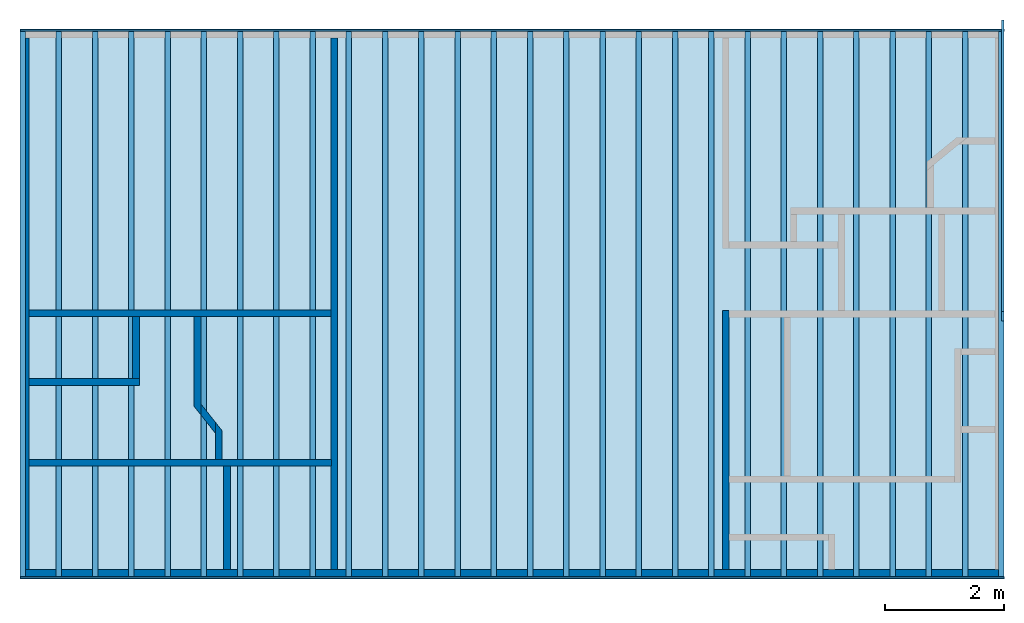
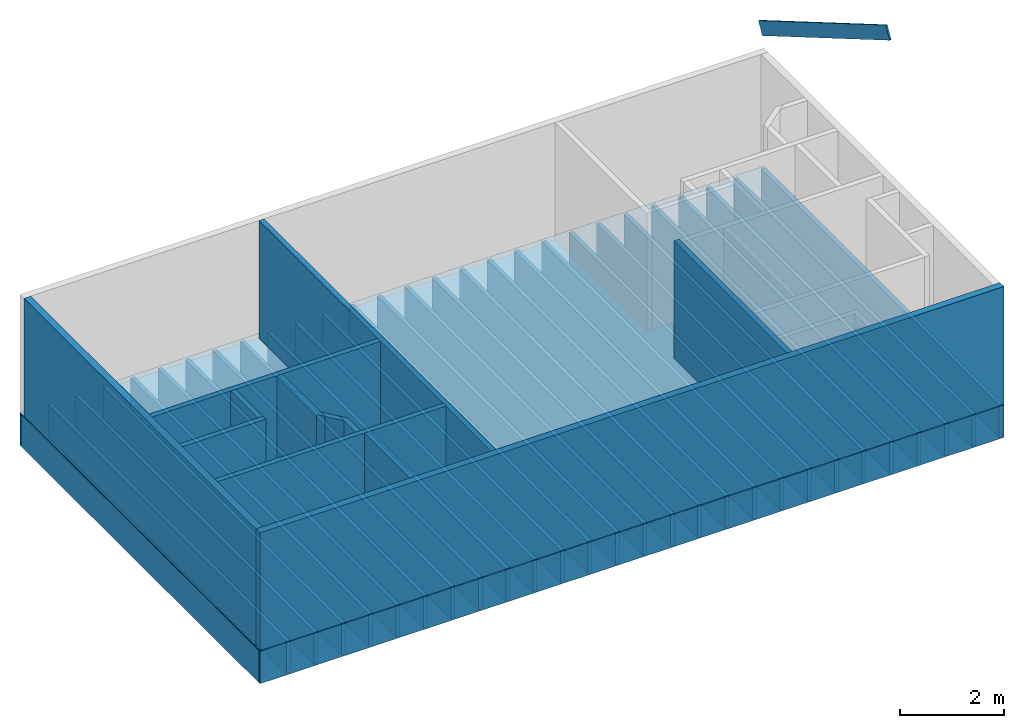
# One storey, part 1 of 2: 30 beams, 12 walls, 3 members, 1 slab.
"""IFC4 building model written with IfcOpenShell, lengths in inches."""

from ifc_helpers import new_model, entity, si_unit, converted_unit, frame, origin_with_axes, origin_2d_with_axis, place, context, subcontext, project, spatial, line, indexed_curve, outline, extrude, clip, halfspace, material, layer, layer_set, layer_usage, type_object, element, save


model = new_model("IFC4")

# Units and contexts
model_context = context("Model", 3, precision=1e-05, world=origin_with_axes())
plan_context = context("Plan", 2, precision=1e-05, world=origin_2d_with_axis())
body_context = subcontext(model_context, "Body", "Model", "MODEL_VIEW")
ifc_project = project(units=[converted_unit("PLANEANGLEUNIT", "degree", entity("IfcReal", 0.0174532925199433), si_unit("PLANEANGLEUNIT", "RADIAN"), dimensions=[0, 0, 0, 0, 0, 0, 0]), converted_unit("AREAUNIT", "square inch", entity("IfcReal", 0.0006452), si_unit("AREAUNIT", "SQUARE_METRE"), dimensions=[2, 0, 0, 0, 0, 0, 0]), converted_unit("LENGTHUNIT", "inch", entity("IfcReal", 0.0254), si_unit("LENGTHUNIT", "METRE"), dimensions=[1, 0, 0, 0, 0, 0, 0]), converted_unit("VOLUMEUNIT", "cubic inch", entity("IfcReal", 1.639e-05), si_unit("VOLUMEUNIT", "CUBIC_METRE"), dimensions=[3, 0, 0, 0, 0, 0, 0])], contexts=[model_context, plan_context])

# Site, building, storey
site_placement = place(None, origin_with_axes())
site = spatial("IfcSite", under=ifc_project, at=site_placement)
building_placement = place(site_placement, frame((0.0, 0.0, 109.012492998378), z_axis=(0.0, 0.0, 1.0), x_axis=(1.0, 0.0, 0.0)))
building = spatial("IfcBuilding", under=site, at=building_placement, Name="Building")
storey_placement = place(building_placement, frame((0.0, 0.0, -109.012492998378), z_axis=(0.0, 0.0, 1.0), x_axis=(1.0, 0.0, 0.0)))
storey = spatial("IfcBuildingStorey", under=building, at=storey_placement, Name="1st Floor")

# Beams
ifc_material = material(Name="Default")
ifc_layer_1 = layer(ifc_material, 1.25, Name="1.25in rim joist")
ifc_layer_set_1 = layer_set([ifc_layer_1], Name="1.25in rim joist")
ifc_layer_usage_1 = layer_usage(ifc_layer_set_1, "AXIS2", "POSITIVE", 0.0)
beam_type_1 = type_object("IfcBeamType", Name="1.25in rim joist", PredefinedType="JOIST", material=ifc_layer_set_1)
beam_1_placement = place(storey_placement, frame((-18.4998631946684, 4.74999974093099, -30.7187508410356), z_axis=(0.0, 0.0, 1.0), x_axis=(1.0, 0.0, 0.0)))
element("IfcBeam", 1, at=beam_1_placement, inside=storey, type_object=beam_type_1, material=ifc_layer_usage_1, Name="Beam", PredefinedType="NOTDEFINED", context=body_context, shape_type="SweptSolid", body=[
    extrude(outline(indexed_curve([(0.0, 0.0), (0.0, 1.25), (651.499983345347, 1.25), (651.499983345347, 0.0), (0.0, 0.0)], self_intersect=False)), origin_with_axes(), (0.0, 0.0, 1.0), 30.0),
])
ifc_layer_usage_2 = layer_usage(ifc_layer_set_1, "AXIS2", "POSITIVE", 0.0)
beam_2_placement = place(storey_placement, frame((-18.4998631946684, -357.879090496874, -30.7187508410356), z_axis=(0.0, 0.0, 1.0), x_axis=(1.0, 0.0, 0.0)))
element("IfcBeam", 2, at=beam_2_placement, inside=storey, type_object=beam_type_1, material=ifc_layer_usage_2, Name="Beam", PredefinedType="NOTDEFINED", context=body_context, shape_type="SweptSolid", body=[
    extrude(outline(indexed_curve([(0.0, 0.0), (0.0, 1.25), (651.499983345347, 1.25), (651.499983345347, 0.0), (0.0, 0.0)], self_intersect=False)), origin_with_axes(), (0.0, 0.0, 1.0), 30.0),
])
ifc_layer_2 = layer(ifc_material, 3.5, Name="FloorTruss 3.5 in top/bottom")
ifc_layer_set_2 = layer_set([ifc_layer_2], Name="FloorTruss 3.5 in top/bottom")
ifc_layer_usage_3 = layer_usage(ifc_layer_set_2, "AXIS2", "POSITIVE", 0.0)
beam_type_2 = type_object("IfcBeamType", Name="FloorTruss 3.5 in top/bottom", PredefinedType="JOIST", material=ifc_layer_set_2)
beam_3_placement = place(storey_placement, frame((104.999683034702, -356.628650755394, -30.7187508410356), z_axis=(0.0, 0.0, 1.0), x_axis=(3.13916473260178e-07, 1.0, 0.0)))
element("IfcBeam", 3, at=beam_3_placement, inside=storey, type_object=beam_type_2, material=ifc_layer_usage_3, Name="Beam", PredefinedType="NOTDEFINED", context=body_context, shape_type="SweptSolid", body=[
    extrude(outline(indexed_curve([(0.0, 0.0), (0.0, 3.5), (361.378694567074, 3.5), (361.378694567074, 0.0), (0.0, 0.0)], self_intersect=False)), origin_with_axes(), (0.0, 0.0, 1.0), 30.0),
])
ifc_layer_usage_4 = layer_usage(ifc_layer_set_2, "AXIS2", "POSITIVE", 0.0)
beam_4_placement = place(storey_placement, frame((128.999676291398, -356.628650755394, -30.7187508410356), z_axis=(0.0, 0.0, 1.0), x_axis=(3.13916473260178e-07, 1.0, 0.0)))
element("IfcBeam", 4, at=beam_4_placement, inside=storey, type_object=beam_type_2, material=ifc_layer_usage_4, Name="Beam", PredefinedType="NOTDEFINED", context=body_context, shape_type="SweptSolid", body=[
    extrude(outline(indexed_curve([(0.0, 0.0), (0.0, 3.5), (361.378694567074, 3.5), (361.378694567074, 0.0), (0.0, 0.0)], self_intersect=False)), origin_with_axes(), (0.0, 0.0, 1.0), 30.0),
])
ifc_layer_usage_5 = layer_usage(ifc_layer_set_2, "AXIS2", "POSITIVE", 0.0)
beam_5_placement = place(storey_placement, frame((152.999669548095, -356.628650755394, -30.7187508410356), z_axis=(0.0, 0.0, 1.0), x_axis=(3.13916473260178e-07, 1.0, 0.0)))
element("IfcBeam", 5, at=beam_5_placement, inside=storey, type_object=beam_type_2, material=ifc_layer_usage_5, Name="Beam", PredefinedType="NOTDEFINED", context=body_context, shape_type="SweptSolid", body=[
    extrude(outline(indexed_curve([(0.0, 0.0), (0.0, 3.5), (361.378694567074, 3.5), (361.378694567074, 0.0), (0.0, 0.0)], self_intersect=False)), origin_with_axes(), (0.0, 0.0, 1.0), 30.0),
])
ifc_layer_usage_6 = layer_usage(ifc_layer_set_2, "AXIS2", "POSITIVE", 0.0)
beam_6_placement = place(storey_placement, frame((176.999662804791, -356.628650755394, -30.7187508410356), z_axis=(0.0, 0.0, 1.0), x_axis=(3.13916473260178e-07, 1.0, 0.0)))
element("IfcBeam", 6, at=beam_6_placement, inside=storey, type_object=beam_type_2, material=ifc_layer_usage_6, Name="Beam", PredefinedType="NOTDEFINED", context=body_context, shape_type="SweptSolid", body=[
    extrude(outline(indexed_curve([(0.0, 0.0), (0.0, 3.5), (361.378694567074, 3.5), (361.378694567074, 0.0), (0.0, 0.0)], self_intersect=False)), origin_with_axes(), (0.0, 0.0, 1.0), 30.0),
])
ifc_layer_usage_7 = layer_usage(ifc_layer_set_2, "AXIS2", "POSITIVE", 0.0)
beam_7_placement = place(storey_placement, frame((200.999665448046, -356.628650755394, -30.7187508410356), z_axis=(0.0, 0.0, 1.0), x_axis=(3.13916473260178e-07, 1.0, 0.0)))
element("IfcBeam", 7, at=beam_7_placement, inside=storey, type_object=beam_type_2, material=ifc_layer_usage_7, Name="Beam", PredefinedType="NOTDEFINED", context=body_context, shape_type="SweptSolid", body=[
    extrude(outline(indexed_curve([(0.0, 0.0), (0.0, 3.5), (361.378694567074, 3.5), (361.378694567074, 0.0), (0.0, 0.0)], self_intersect=False)), origin_with_axes(), (0.0, 0.0, 1.0), 30.0),
])
ifc_layer_usage_8 = layer_usage(ifc_layer_set_2, "AXIS2", "POSITIVE", 0.0)
beam_8_placement = place(storey_placement, frame((224.999668091301, -356.628650755394, -30.7187508410356), z_axis=(0.0, 0.0, 1.0), x_axis=(3.13916473260178e-07, 1.0, 0.0)))
element("IfcBeam", 8, at=beam_8_placement, inside=storey, type_object=beam_type_2, material=ifc_layer_usage_8, Name="Beam", PredefinedType="NOTDEFINED", context=body_context, shape_type="SweptSolid", body=[
    extrude(outline(indexed_curve([(0.0, 0.0), (0.0, 3.5), (361.378694567074, 3.5), (361.378694567074, 0.0), (0.0, 0.0)], self_intersect=False)), origin_with_axes(), (0.0, 0.0, 1.0), 30.0),
])
ifc_layer_usage_9 = layer_usage(ifc_layer_set_2, "AXIS2", "POSITIVE", 0.0)
beam_9_placement = place(storey_placement, frame((248.999670734556, -356.628650755394, -30.7187508410356), z_axis=(0.0, 0.0, 1.0), x_axis=(3.13916473260178e-07, 1.0, 0.0)))
element("IfcBeam", 9, at=beam_9_placement, inside=storey, type_object=beam_type_2, material=ifc_layer_usage_9, Name="Beam", PredefinedType="NOTDEFINED", context=body_context, shape_type="SweptSolid", body=[
    extrude(outline(indexed_curve([(0.0, 0.0), (0.0, 3.5), (361.378694567074, 3.5), (361.378694567074, 0.0), (0.0, 0.0)], self_intersect=False)), origin_with_axes(), (0.0, 0.0, 1.0), 30.0),
])
ifc_layer_usage_10 = layer_usage(ifc_layer_set_2, "AXIS2", "POSITIVE", 0.0)
beam_10_placement = place(storey_placement, frame((272.99967337781, -356.628650755394, -30.7187508410356), z_axis=(0.0, 0.0, 1.0), x_axis=(3.13916473260178e-07, 1.0, 0.0)))
element("IfcBeam", 10, at=beam_10_placement, inside=storey, type_object=beam_type_2, material=ifc_layer_usage_10, Name="Beam", PredefinedType="NOTDEFINED", context=body_context, shape_type="SweptSolid", body=[
    extrude(outline(indexed_curve([(0.0, 0.0), (0.0, 3.5), (361.378694567074, 3.5), (361.378694567074, 0.0), (0.0, 0.0)], self_intersect=False)), origin_with_axes(), (0.0, 0.0, 1.0), 30.0),
])
ifc_layer_usage_11 = layer_usage(ifc_layer_set_2, "AXIS2", "POSITIVE", 0.0)
beam_11_placement = place(storey_placement, frame((296.999676021065, -356.628650755394, -30.7187508410356), z_axis=(0.0, 0.0, 1.0), x_axis=(3.13916473260178e-07, 1.0, 0.0)))
element("IfcBeam", 11, at=beam_11_placement, inside=storey, type_object=beam_type_2, material=ifc_layer_usage_11, Name="Beam", PredefinedType="NOTDEFINED", context=body_context, shape_type="SweptSolid", body=[
    extrude(outline(indexed_curve([(0.0, 0.0), (0.0, 3.5), (361.378694567074, 3.5), (361.378694567074, 0.0), (0.0, 0.0)], self_intersect=False)), origin_with_axes(), (0.0, 0.0, 1.0), 30.0),
])
ifc_layer_usage_12 = layer_usage(ifc_layer_set_2, "AXIS2", "POSITIVE", 0.0)
beam_12_placement = place(storey_placement, frame((320.99967866432, -356.628650755394, -30.7187508410356), z_axis=(0.0, 0.0, 1.0), x_axis=(3.13916473260178e-07, 1.0, 0.0)))
element("IfcBeam", 12, at=beam_12_placement, inside=storey, type_object=beam_type_2, material=ifc_layer_usage_12, Name="Beam", PredefinedType="NOTDEFINED", context=body_context, shape_type="SweptSolid", body=[
    extrude(outline(indexed_curve([(0.0, 0.0), (0.0, 3.5), (361.378694567074, 3.5), (361.378694567074, 0.0), (0.0, 0.0)], self_intersect=False)), origin_with_axes(), (0.0, 0.0, 1.0), 30.0),
])
ifc_layer_usage_13 = layer_usage(ifc_layer_set_2, "AXIS2", "POSITIVE", 0.0)
beam_13_placement = place(storey_placement, frame((344.999681307575, -356.628650755394, -30.7187508410356), z_axis=(0.0, 0.0, 1.0), x_axis=(3.13916473260178e-07, 1.0, 0.0)))
element("IfcBeam", 13, at=beam_13_placement, inside=storey, type_object=beam_type_2, material=ifc_layer_usage_13, Name="Beam", PredefinedType="NOTDEFINED", context=body_context, shape_type="SweptSolid", body=[
    extrude(outline(indexed_curve([(0.0, 0.0), (0.0, 3.5), (361.378694567074, 3.5), (361.378694567074, 0.0), (0.0, 0.0)], self_intersect=False)), origin_with_axes(), (0.0, 0.0, 1.0), 30.0),
])
ifc_layer_usage_14 = layer_usage(ifc_layer_set_2, "AXIS2", "POSITIVE", 0.0)
beam_14_placement = place(storey_placement, frame((368.999721497063, -356.628650755394, -30.7187508410356), z_axis=(0.0, 0.0, 1.0), x_axis=(3.13916473260178e-07, 1.0, 0.0)))
element("IfcBeam", 14, at=beam_14_placement, inside=storey, type_object=beam_type_2, material=ifc_layer_usage_14, Name="Beam", PredefinedType="NOTDEFINED", context=body_context, shape_type="SweptSolid", body=[
    extrude(outline(indexed_curve([(0.0, 0.0), (0.0, 3.5), (361.378694567074, 3.5), (361.378694567074, 0.0), (0.0, 0.0)], self_intersect=False)), origin_with_axes(), (0.0, 0.0, 1.0), 30.0),
])
ifc_layer_usage_15 = layer_usage(ifc_layer_set_2, "AXIS2", "POSITIVE", 0.0)
beam_15_placement = place(storey_placement, frame((392.999724140317, -356.628650755394, -30.7187508410356), z_axis=(0.0, 0.0, 1.0), x_axis=(3.13916473260178e-07, 1.0, 0.0)))
element("IfcBeam", 15, at=beam_15_placement, inside=storey, type_object=beam_type_2, material=ifc_layer_usage_15, Name="Beam", PredefinedType="NOTDEFINED", context=body_context, shape_type="SweptSolid", body=[
    extrude(outline(indexed_curve([(0.0, 0.0), (0.0, 3.5), (361.378694567074, 3.5), (361.378694567074, 0.0), (0.0, 0.0)], self_intersect=False)), origin_with_axes(), (0.0, 0.0, 1.0), 30.0),
])
ifc_layer_usage_16 = layer_usage(ifc_layer_set_2, "AXIS2", "POSITIVE", 0.0)
beam_16_placement = place(storey_placement, frame((416.999726783572, -356.628650755394, -30.7187508410356), z_axis=(0.0, 0.0, 1.0), x_axis=(3.13916473260178e-07, 1.0, 0.0)))
element("IfcBeam", 16, at=beam_16_placement, inside=storey, type_object=beam_type_2, material=ifc_layer_usage_16, Name="Beam", PredefinedType="NOTDEFINED", context=body_context, shape_type="SweptSolid", body=[
    extrude(outline(indexed_curve([(0.0, 0.0), (0.0, 3.5), (361.378694567074, 3.5), (361.378694567074, 0.0), (0.0, 0.0)], self_intersect=False)), origin_with_axes(), (0.0, 0.0, 1.0), 30.0),
])
ifc_layer_usage_17 = layer_usage(ifc_layer_set_2, "AXIS2", "POSITIVE", 0.0)
beam_17_placement = place(storey_placement, frame((440.999729426827, -356.628650755394, -30.7187508410356), z_axis=(0.0, 0.0, 1.0), x_axis=(3.13916473260178e-07, 1.0, 0.0)))
element("IfcBeam", 17, at=beam_17_placement, inside=storey, type_object=beam_type_2, material=ifc_layer_usage_17, Name="Beam", PredefinedType="NOTDEFINED", context=body_context, shape_type="SweptSolid", body=[
    extrude(outline(indexed_curve([(0.0, 0.0), (0.0, 3.5), (361.378694567074, 3.5), (361.378694567074, 0.0), (0.0, 0.0)], self_intersect=False)), origin_with_axes(), (0.0, 0.0, 1.0), 30.0),
])
ifc_layer_usage_18 = layer_usage(ifc_layer_set_2, "AXIS2", "POSITIVE", 0.0)
beam_18_placement = place(storey_placement, frame((464.999732070082, -356.628650755394, -30.7187508410356), z_axis=(0.0, 0.0, 1.0), x_axis=(3.13916473260178e-07, 1.0, 0.0)))
element("IfcBeam", 18, at=beam_18_placement, inside=storey, type_object=beam_type_2, material=ifc_layer_usage_18, Name="Beam", PredefinedType="NOTDEFINED", context=body_context, shape_type="SweptSolid", body=[
    extrude(outline(indexed_curve([(0.0, 0.0), (0.0, 3.5), (361.378694567074, 3.5), (361.378694567074, 0.0), (0.0, 0.0)], self_intersect=False)), origin_with_axes(), (0.0, 0.0, 1.0), 30.0),
])
ifc_layer_usage_19 = layer_usage(ifc_layer_set_2, "AXIS2", "POSITIVE", 0.0)
beam_19_placement = place(storey_placement, frame((488.999734713337, -356.628650755394, -30.7187508410356), z_axis=(0.0, 0.0, 1.0), x_axis=(3.13916473260178e-07, 1.0, 0.0)))
element("IfcBeam", 19, at=beam_19_placement, inside=storey, type_object=beam_type_2, material=ifc_layer_usage_19, Name="Beam", PredefinedType="NOTDEFINED", context=body_context, shape_type="SweptSolid", body=[
    extrude(outline(indexed_curve([(0.0, 0.0), (0.0, 3.5), (361.378694567074, 3.5), (361.378694567074, 0.0), (0.0, 0.0)], self_intersect=False)), origin_with_axes(), (0.0, 0.0, 1.0), 30.0),
])
ifc_layer_usage_20 = layer_usage(ifc_layer_set_2, "AXIS2", "POSITIVE", 0.0)
beam_20_placement = place(storey_placement, frame((512.999737356591, -356.628650755394, -30.7187508410356), z_axis=(0.0, 0.0, 1.0), x_axis=(3.13916473260178e-07, 1.0, 0.0)))
element("IfcBeam", 20, at=beam_20_placement, inside=storey, type_object=beam_type_2, material=ifc_layer_usage_20, Name="Beam", PredefinedType="NOTDEFINED", context=body_context, shape_type="SweptSolid", body=[
    extrude(outline(indexed_curve([(0.0, 0.0), (0.0, 3.5), (361.378694567074, 3.5), (361.378694567074, 0.0), (0.0, 0.0)], self_intersect=False)), origin_with_axes(), (0.0, 0.0, 1.0), 30.0),
])
ifc_layer_usage_21 = layer_usage(ifc_layer_set_2, "AXIS2", "POSITIVE", 0.0)
beam_21_placement = place(storey_placement, frame((536.999739999846, -356.628650755394, -30.7187508410356), z_axis=(0.0, 0.0, 1.0), x_axis=(3.13916473260178e-07, 1.0, 0.0)))
element("IfcBeam", 21, at=beam_21_placement, inside=storey, type_object=beam_type_2, material=ifc_layer_usage_21, Name="Beam", PredefinedType="NOTDEFINED", context=body_context, shape_type="SweptSolid", body=[
    extrude(outline(indexed_curve([(0.0, 0.0), (0.0, 3.5), (361.378694567074, 3.5), (361.378694567074, 0.0), (0.0, 0.0)], self_intersect=False)), origin_with_axes(), (0.0, 0.0, 1.0), 30.0),
])
ifc_layer_usage_22 = layer_usage(ifc_layer_set_2, "AXIS2", "POSITIVE", 0.0)
beam_22_placement = place(storey_placement, frame((560.999742643101, -356.628650755394, -30.7187508410356), z_axis=(0.0, 0.0, 1.0), x_axis=(3.13916473260178e-07, 1.0, 0.0)))
element("IfcBeam", 22, at=beam_22_placement, inside=storey, type_object=beam_type_2, material=ifc_layer_usage_22, Name="Beam", PredefinedType="NOTDEFINED", context=body_context, shape_type="SweptSolid", body=[
    extrude(outline(indexed_curve([(0.0, 0.0), (0.0, 3.5), (361.378694567074, 3.5), (361.378694567074, 0.0), (0.0, 0.0)], self_intersect=False)), origin_with_axes(), (0.0, 0.0, 1.0), 30.0),
])
ifc_layer_usage_23 = layer_usage(ifc_layer_set_2, "AXIS2", "POSITIVE", 0.0)
beam_23_placement = place(storey_placement, frame((584.999745286356, -356.628650755394, -30.7187508410356), z_axis=(0.0, 0.0, 1.0), x_axis=(3.13916473260178e-07, 1.0, 0.0)))
element("IfcBeam", 23, at=beam_23_placement, inside=storey, type_object=beam_type_2, material=ifc_layer_usage_23, Name="Beam", PredefinedType="NOTDEFINED", context=body_context, shape_type="SweptSolid", body=[
    extrude(outline(indexed_curve([(0.0, 0.0), (0.0, 3.5), (361.378694567074, 3.5), (361.378694567074, 0.0), (0.0, 0.0)], self_intersect=False)), origin_with_axes(), (0.0, 0.0, 1.0), 30.0),
])
ifc_layer_usage_24 = layer_usage(ifc_layer_set_2, "AXIS2", "POSITIVE", 0.0)
beam_24_placement = place(storey_placement, frame((608.999747929611, -356.628650755394, -30.7187508410356), z_axis=(0.0, 0.0, 1.0), x_axis=(3.13916473260178e-07, 1.0, 0.0)))
element("IfcBeam", 24, at=beam_24_placement, inside=storey, type_object=beam_type_2, material=ifc_layer_usage_24, Name="Beam", PredefinedType="NOTDEFINED", context=body_context, shape_type="SweptSolid", body=[
    extrude(outline(indexed_curve([(0.0, 0.0), (0.0, 3.5), (361.378694567074, 3.5), (361.378694567074, 0.0), (0.0, 0.0)], self_intersect=False)), origin_with_axes(), (0.0, 0.0, 1.0), 30.0),
])
ifc_layer_usage_25 = layer_usage(ifc_layer_set_2, "AXIS2", "POSITIVE", 0.0)
beam_25_placement = place(storey_placement, frame((632.999825665331, -356.628650755394, -30.7187508410356), z_axis=(0.0, 0.0, 1.0), x_axis=(3.13916473260178e-07, 1.0, 0.0)))
element("IfcBeam", 25, at=beam_25_placement, inside=storey, type_object=beam_type_2, material=ifc_layer_usage_25, Name="Beam", PredefinedType="NOTDEFINED", context=body_context, shape_type="SweptSolid", body=[
    extrude(outline(indexed_curve([(0.0, 0.0), (0.0, 3.5), (361.378694567074, 3.5), (361.378694567074, 0.0), (0.0, 0.0)], self_intersect=False)), origin_with_axes(), (0.0, 0.0, 1.0), 30.0),
])
ifc_layer_usage_26 = layer_usage(ifc_layer_set_2, "AXIS2", "POSITIVE", 0.0)
beam_26_placement = place(storey_placement, frame((80.9996710048886, -356.628650755394, -30.7187508410356), z_axis=(0.0, 0.0, 1.0), x_axis=(3.13916473260178e-07, 1.0, 0.0)))
element("IfcBeam", 26, at=beam_26_placement, inside=storey, type_object=beam_type_2, material=ifc_layer_usage_26, Name="Beam", PredefinedType="NOTDEFINED", context=body_context, shape_type="SweptSolid", body=[
    extrude(outline(indexed_curve([(0.0, 0.0), (0.0, 3.5), (361.378694567074, 3.5), (361.378694567074, 0.0), (0.0, 0.0)], self_intersect=False)), origin_with_axes(), (0.0, 0.0, 1.0), 30.0),
])
ifc_layer_usage_27 = layer_usage(ifc_layer_set_2, "AXIS2", "POSITIVE", 0.0)
beam_27_placement = place(storey_placement, frame((56.9996730549129, -356.628650755394, -30.7187508410356), z_axis=(0.0, 0.0, 1.0), x_axis=(3.13916473260178e-07, 1.0, 0.0)))
element("IfcBeam", 27, at=beam_27_placement, inside=storey, type_object=beam_type_2, material=ifc_layer_usage_27, Name="Beam", PredefinedType="NOTDEFINED", context=body_context, shape_type="SweptSolid", body=[
    extrude(outline(indexed_curve([(0.0, 0.0), (0.0, 3.5), (361.378694567074, 3.5), (361.378694567074, 0.0), (0.0, 0.0)], self_intersect=False)), origin_with_axes(), (0.0, 0.0, 1.0), 30.0),
])
ifc_layer_usage_28 = layer_usage(ifc_layer_set_2, "AXIS2", "POSITIVE", 0.0)
beam_28_placement = place(storey_placement, frame((32.9996704116581, -356.628650755394, -30.7187508410356), z_axis=(0.0, 0.0, 1.0), x_axis=(3.13916473260178e-07, 1.0, 0.0)))
element("IfcBeam", 28, at=beam_28_placement, inside=storey, type_object=beam_type_2, material=ifc_layer_usage_28, Name="Beam", PredefinedType="NOTDEFINED", context=body_context, shape_type="SweptSolid", body=[
    extrude(outline(indexed_curve([(0.0, 0.0), (0.0, 3.5), (361.378694567074, 3.5), (361.378694567074, 0.0), (0.0, 0.0)], self_intersect=False)), origin_with_axes(), (0.0, 0.0, 1.0), 30.0),
])
ifc_layer_usage_29 = layer_usage(ifc_layer_set_2, "AXIS2", "POSITIVE", 0.0)
beam_29_placement = place(storey_placement, frame((8.99967246168242, -356.628650755394, -30.7187508410356), z_axis=(0.0, 0.0, 1.0), x_axis=(3.13916473260178e-07, 1.0, 0.0)))
element("IfcBeam", 29, at=beam_29_placement, inside=storey, type_object=beam_type_2, material=ifc_layer_usage_29, Name="Beam", PredefinedType="NOTDEFINED", context=body_context, shape_type="SweptSolid", body=[
    extrude(outline(indexed_curve([(0.0, 0.0), (0.0, 3.5), (361.378694567074, 3.5), (361.378694567074, 0.0), (0.0, 0.0)], self_intersect=False)), origin_with_axes(), (0.0, 0.0, 1.0), 30.0),
])
ifc_layer_usage_30 = layer_usage(ifc_layer_set_2, "AXIS2", "POSITIVE", 0.0)
beam_30_placement = place(storey_placement, frame((-15.0003301815724, -356.628650755394, -30.7187508410356), z_axis=(0.0, 0.0, 1.0), x_axis=(3.13916473260178e-07, 1.0, 0.0)))
element("IfcBeam", 30, at=beam_30_placement, inside=storey, type_object=beam_type_2, material=ifc_layer_usage_30, Name="Beam", PredefinedType="NOTDEFINED", context=body_context, shape_type="SweptSolid", body=[
    extrude(outline(indexed_curve([(0.0, 0.0), (0.0, 3.5), (361.378694567074, 3.5), (361.378694567074, 0.0), (0.0, 0.0)], self_intersect=False)), origin_with_axes(), (0.0, 0.0, 1.0), 30.0),
])

# Members
ifc_layer_3 = layer(ifc_material, 1.5)
ifc_layer_set_3 = layer_set([ifc_layer_3])
ifc_layer_usage_31 = layer_usage(ifc_layer_set_3, "AXIS2", "POSITIVE", 0.0)
member_type = type_object("IfcMemberType", Name="2x12 wood rafter", PredefinedType="RAFTER", material=ifc_layer_set_3)
member_1_placement = place(storey_placement, frame((631.500003844734, 6.00000007415381, 121.012494320006), z_axis=(-5.96369176264488e-08, 0.504527628421783, 0.863395571708679), x_axis=(-1.06698792023963e-06, -0.863395571708679, 0.504527628421783)))
element("IfcMember", 31, at=member_1_placement, inside=storey, type_object=member_type, material=ifc_layer_usage_31, Name="Member", PredefinedType="NOTDEFINED", context=body_context, shape_type="SweptSolid", body=[
    extrude(outline(indexed_curve([(0.0, 0.0), (0.0, 1.5), (223.635576889743, 1.5), (223.635576889743, 0.0), (0.0, 0.0)], self_intersect=False)), origin_with_axes(), (0.0, 0.0, 1.0), 12.0),
])
ifc_layer_usage_32 = layer_usage(ifc_layer_set_3, "AXIS2", "POSITIVE", 0.0)
member_2_placement = place(storey_placement, frame((631.500003844734, 6.00000007415381, 121.012494320006), z_axis=(-5.96369176264488e-08, 0.504527628421783, 0.863395571708679), x_axis=(-1.06698792023963e-06, -0.863395571708679, 0.504527628421783)))
element("IfcMember", 32, at=member_2_placement, inside=storey, type_object=member_type, material=ifc_layer_usage_32, Name="Member", PredefinedType="NOTDEFINED", context=body_context, shape_type="SweptSolid", body=[
    extrude(outline(indexed_curve([(0.0, 0.0), (0.0, 1.5), (223.635576889743, 1.5), (223.635576889743, 0.0), (0.0, 0.0)], self_intersect=False)), origin_with_axes(), (0.0, 0.0, 1.0), 12.0),
])
ifc_layer_usage_33 = layer_usage(ifc_layer_set_3, "AXIS2", "POSITIVE", 0.0)
member_3_placement = place(storey_placement, frame((631.500003844734, 6.00000007415381, 121.012494320006), z_axis=(-5.96369176264488e-08, 0.504527628421783, 0.863395571708679), x_axis=(-1.06698792023963e-06, -0.863395571708679, 0.504527628421783)))
element("IfcMember", 33, at=member_3_placement, inside=storey, type_object=member_type, material=ifc_layer_usage_33, Name="Member", PredefinedType="NOTDEFINED", context=body_context, shape_type="SweptSolid", body=[
    extrude(outline(indexed_curve([(0.0, 0.0), (0.0, 1.5), (223.635576889743, 1.5), (223.635576889743, 0.0), (0.0, 0.0)], self_intersect=False)), origin_with_axes(), (0.0, 0.0, 1.0), 12.0),
])

# Slab
ifc_layer_4 = layer(ifc_material, 0.71875, Name="osb floor")
ifc_layer_set_4 = layer_set([ifc_layer_4], Name="osb floor")
ifc_layer_usage_34 = layer_usage(ifc_layer_set_4, "AXIS3", "POSITIVE", 0.0)
slab_type = type_object("IfcSlabType", Name="23/32 floor osb", PredefinedType="FLOOR", material=ifc_layer_set_4)
slab_placement = place(storey_placement, frame((-18.4998045286794, -68.7937004359688, -0.71875003027165), z_axis=(0.0, 0.0, 1.0), x_axis=(1.0, 0.0, 0.0)))
element("IfcSlab", 34, at=slab_placement, inside=storey, type_object=slab_type, material=ifc_layer_usage_34, Name="Slab", PredefinedType="NOTDEFINED", context=body_context, shape_type="SweptSolid", body=[
    extrude(outline(indexed_curve([(651.499905924159, 74.7933068613368), (651.499905924159, -289.085324354998), (-2.34663955808625e-06, -289.084930119552), (2.34663955808625e-06, 74.7937010967825)], segments=[line(3, 2), line(2, 1), line(1, 4), line(4, 3)], self_intersect=False)), None, (0.0, 0.0, 1.0), 0.71875),
])

# Walls
ifc_layer_5 = layer(ifc_material, 6.0, Name="6in")
ifc_layer_set_5 = layer_set([ifc_layer_5], Name="6in")
ifc_layer_usage_35 = layer_usage(ifc_layer_set_5, "AXIS2", "POSITIVE", 0.0)
wall_type_1 = type_object("IfcWallType", Name="6in wall", PredefinedType="ELEMENTEDWALL", material=ifc_layer_set_5)
wall_1_placement = place(storey_placement, frame((-18.4998080486388, 0.0, 0.0), z_axis=(0.0, 0.0, 1.0), x_axis=(-1.62920684942947e-07, -1.0, 0.0)))
element("IfcWall", 35, at=wall_1_placement, inside=storey, type_object=wall_type_1, material=ifc_layer_usage_35, Name="Wall", PredefinedType="NOTDEFINED", context=body_context, shape_type="SweptSolid", body=[
    extrude(outline(indexed_curve([(0.0, 0.0), (0.0, 6.0), (351.878934288478, 6.0), (351.878934288478, 0.0), (0.0, 0.0)], self_intersect=False)), origin_with_axes(), (0.0, 0.0, 1.0), 109.012496948242),
])
ifc_layer_usage_36 = layer_usage(ifc_layer_set_5, "AXIS2", "POSITIVE", 0.0)
wall_2_placement = place(storey_placement, frame((-18.4998690612673, -357.878940311943, 0.0), z_axis=(0.0, 0.0, 1.0), x_axis=(1.0, -2.38418579101562e-07, 0.0)))
element("IfcWall", 36, at=wall_2_placement, inside=storey, type_object=wall_type_1, material=ifc_layer_usage_36, Name="Wall", PredefinedType="NOTDEFINED", context=body_context, shape_type="SweptSolid", body=[
    extrude(outline(indexed_curve([(0.0, 0.0), (0.0, 6.0), (651.499765529479, 6.0), (651.499765529479, 0.0), (0.0, 0.0)], self_intersect=False)), origin_with_axes(), (0.0, 0.0, 1.0), 109.012496948242),
])
ifc_layer_6 = layer(ifc_material, 4.5, Name="4.5 wall")
ifc_layer_set_6 = layer_set([ifc_layer_6], Name="4.5 wall")
ifc_layer_usage_37 = layer_usage(ifc_layer_set_6, "AXIS2", "POSITIVE", 0.0)
wall_type_2 = type_object("IfcWallType", Name="4.5 in inter stud wall", PredefinedType="ELEMENTEDWALL", material=ifc_layer_set_6)
wall_3_placement = place(storey_placement, frame((-12.4998378941393, -184.371114715816, 0.0), z_axis=(0.0, 0.0, 1.0), x_axis=(1.0, -2.38418579101562e-07, 0.0)))
element("IfcWall", 37, at=wall_3_placement, inside=storey, type_object=wall_type_2, material=ifc_layer_usage_37, Name="Wall", PredefinedType="NOTDEFINED", context=body_context, shape_type="SweptSolid", body=[
    extrude(outline(indexed_curve([(0.0, 0.0), (0.0, 4.5), (199.84288828658, 4.5), (199.84288828658, 0.0), (0.0, 0.0)], self_intersect=False)), origin_with_axes(), (0.0, 0.0, 1.0), 109.012496948242),
])
ifc_layer_usage_38 = layer_usage(ifc_layer_set_6, "AXIS2", "POSITIVE", 0.0)
wall_4_placement = place(storey_placement, frame((187.343049237109, 0.0, 0.0), z_axis=(0.0, 0.0, 1.0), x_axis=(-1.62920684942947e-07, -1.0, 0.0)))
element("IfcWall", 38, at=wall_4_placement, inside=storey, type_object=wall_type_2, material=ifc_layer_usage_38, Name="Wall", PredefinedType="NOTDEFINED", context=body_context, shape_type="SweptSolid", body=[
    extrude(outline(indexed_curve([(0.0, 0.0), (0.0, 4.5), (351.878934288478, 4.5), (351.878934288478, 0.0), (0.0, 0.0)], self_intersect=False)), origin_with_axes(), (0.0, 0.0, 1.0), 109.012496948242),
])
ifc_layer_usage_39 = layer_usage(ifc_layer_set_6, "AXIS2", "POSITIVE", 0.0)
wall_5_placement = place(storey_placement, frame((-12.4998531472965, -283.281615399939, 0.0), z_axis=(0.0, 0.0, 1.0), x_axis=(1.0, -2.38418579101562e-07, 0.0)))
element("IfcWall", 39, at=wall_5_placement, inside=storey, type_object=wall_type_2, material=ifc_layer_usage_39, Name="Wall", PredefinedType="NOTDEFINED", context=body_context, shape_type="SweptSolid", body=[
    extrude(outline(indexed_curve([(0.0, 0.0), (0.0, 4.5), (200.394999537641, 4.5), (200.394999537641, 0.0), (0.0, 0.0)], self_intersect=False)), origin_with_axes(), (0.0, 0.0, 1.0), 109.012496948242),
])
ifc_layer_usage_40 = layer_usage(ifc_layer_set_6, "AXIS2", "POSITIVE", 0.0)
wall_6_placement = place(storey_placement, frame((116.257132507685, -283.281652946172, 0.0), z_axis=(0.0, 0.0, 1.0), x_axis=(-2.82129974493728e-07, -1.0, 0.0)))
element("IfcWall", 40, at=wall_6_placement, inside=storey, type_object=wall_type_2, material=ifc_layer_usage_40, Name="Wall", PredefinedType="NOTDEFINED", context=body_context, shape_type="SweptSolid", body=[
    extrude(outline(indexed_curve([(0.0, 0.0), (0.0, 4.5), (68.5972864083699, 4.5), (68.5972864083699, 0.0), (0.0, 0.0)], self_intersect=False)), origin_with_axes(), (0.0, 0.0, 1.0), 109.012496948242),
])
ifc_layer_usage_41 = layer_usage(ifc_layer_set_6, "AXIS2", "POSITIVE", 0.0)
wall_7_placement = place(storey_placement, frame((-12.499844934058, -229.833839446541, 0.0), z_axis=(0.0, 0.0, 1.0), x_axis=(1.0, -2.38418579101562e-07, 0.0)))
element("IfcWall", 41, at=wall_7_placement, inside=storey, type_object=wall_type_2, material=ifc_layer_usage_41, Name="Wall", PredefinedType="NOTDEFINED", context=body_context, shape_type="SweptSolid", body=[
    extrude(outline(indexed_curve([(0.0, 0.0), (0.0, 4.5), (73.1128963679298, 4.5), (73.1128963679298, 0.0), (0.0, 0.0)], self_intersect=False)), origin_with_axes(), (0.0, 0.0, 1.0), 109.012496948242),
])
ifc_layer_usage_42 = layer_usage(ifc_layer_set_6, "AXIS2", "POSITIVE", 0.0)
wall_8_placement = place(storey_placement, frame((60.6130521128497, -225.333848337489, 0.0), z_axis=(0.0, 0.0, 1.0), x_axis=(3.13916473260178e-07, 1.0, 0.0)))
element("IfcWall", 42, at=wall_8_placement, inside=storey, type_object=wall_type_2, material=ifc_layer_usage_42, Name="Wall", PredefinedType="NOTDEFINED", context=body_context, shape_type="SweptSolid", body=[
    extrude(outline(indexed_curve([(0.0, 0.0), (0.0, 4.5), (40.962713792373, 4.5), (40.962713792373, 0.0), (0.0, 0.0)], self_intersect=False)), origin_with_axes(), (0.0, 0.0, 1.0), 109.012496948242),
])
ifc_layer_usage_43 = layer_usage(ifc_layer_set_6, "AXIS2", "POSITIVE", 0.0)
wall_9_placement = place(storey_placement, frame((451.034260547067, -351.879089836061, 0.0), z_axis=(0.0, 0.0, 1.0), x_axis=(9.09962921014085e-07, 1.0, 0.0)))
element("IfcWall", 43, at=wall_9_placement, inside=storey, type_object=wall_type_2, material=ifc_layer_usage_43, Name="Wall", PredefinedType="NOTDEFINED", context=body_context, shape_type="SweptSolid", body=[
    extrude(outline(indexed_curve([(0.0, 0.0), (0.0, 4.5), (171.552886749269, 4.5), (171.552886749269, 0.0), (0.0, 0.0)], self_intersect=False)), origin_with_axes(), (0.0, 0.0, 1.0), 109.012496948242),
])
ifc_layer_usage_44 = layer_usage(ifc_layer_set_6, "AXIS2", "POSITIVE", 0.0)
wall_10_placement = place(storey_placement, frame((115.343031920786, -278.781643064003, 0.0), z_axis=(0.0, 0.0, 1.0), x_axis=(3.13916473260178e-07, 1.0, 0.0)))
element("IfcWall", 44, at=wall_10_placement, inside=storey, type_object=wall_type_2, material=ifc_layer_usage_44, Name="Wall", PredefinedType="NOTDEFINED", context=body_context, shape_type="Clipping", body=[
    clip(extrude(outline(indexed_curve([(0.0, 0.0), (0.0, 4.5), (24.5258374937757, 4.5), (24.5258374937757, 0.0), (0.0, 0.0)], self_intersect=False)), origin_with_axes(), (0.0, 0.0, 1.0), 109.012496948242), halfspace(frame((18.8353540390495, 1.22641600811887e-05, 0.0), z_axis=(0.316487401723862, -0.400214791297913, 0.0), x_axis=(0.144538372755051, 0.114300057291985, 0.0)), False)),
])
ifc_layer_usage_45 = layer_usage(ifc_layer_set_6, "AXIS2", "POSITIVE", 0.0)
wall_11_placement = place(storey_placement, frame((96.7632034632165, -184.371152262049, 0.0), z_axis=(0.0, 0.0, 1.0), x_axis=(-2.82129974493728e-07, -1.0, 0.0)))
element("IfcWall", 45, at=wall_11_placement, inside=storey, type_object=wall_type_2, material=ifc_layer_usage_45, Name="Wall", PredefinedType="NOTDEFINED", context=body_context, shape_type="Clipping", body=[
    clip(extrude(outline(indexed_curve([(0.0, 0.0), (0.0, 4.5), (65.025138614177, 4.5), (65.025138614177, 0.0), (0.0, 0.0)], self_intersect=False)), origin_with_axes(), (0.0, 0.0, 1.0), 109.012496948242), halfspace(frame((59.334673280791, -6.33574956278665e-06, 1.47485254904417), z_axis=(0.316487401723862, -0.400213479995728, 0.0), x_axis=(0.144537895917892, 0.114300049841404, 0.0)), False)),
])
ifc_layer_usage_46 = layer_usage(ifc_layer_set_6, "AXIS2", "POSITIVE", 0.0)
wall_12_placement = place(storey_placement, frame((118.872734505361, -264.409789888878, 0.0), z_axis=(0.0, 0.0, 1.0), x_axis=(-0.620281398296356, 0.784379363059998, 0.0)))
element("IfcWall", 46, at=wall_12_placement, inside=storey, type_object=wall_type_2, material=ifc_layer_usage_46, Name="Wall", PredefinedType="NOTDEFINED", context=body_context, shape_type="Clipping", body=[
    clip(clip(extrude(outline(indexed_curve([(0.0, 0.0), (0.0, 4.5), (35.6443704735172, 4.5), (35.6443704735172, 0.0), (0.0, 0.0)], self_intersect=False)), origin_with_axes(), (0.0, 0.0, 1.0), 109.012496948242), halfspace(frame((12.9452558952992, 1.877311646469e-05, 0.0), z_axis=(-0.316486656665802, -0.400214493274689, 0.0), x_axis=(-0.144538253545761, 0.114299789071083, 0.0)), False)), halfspace(frame((28.3896125207736, 0.0, 0.0), z_axis=(0.316486656665802, 0.400214493274689, 0.0), x_axis=(-0.144538253545761, 0.114299789071083, 0.0)), False)),
])

save(model, "model.ifc")
